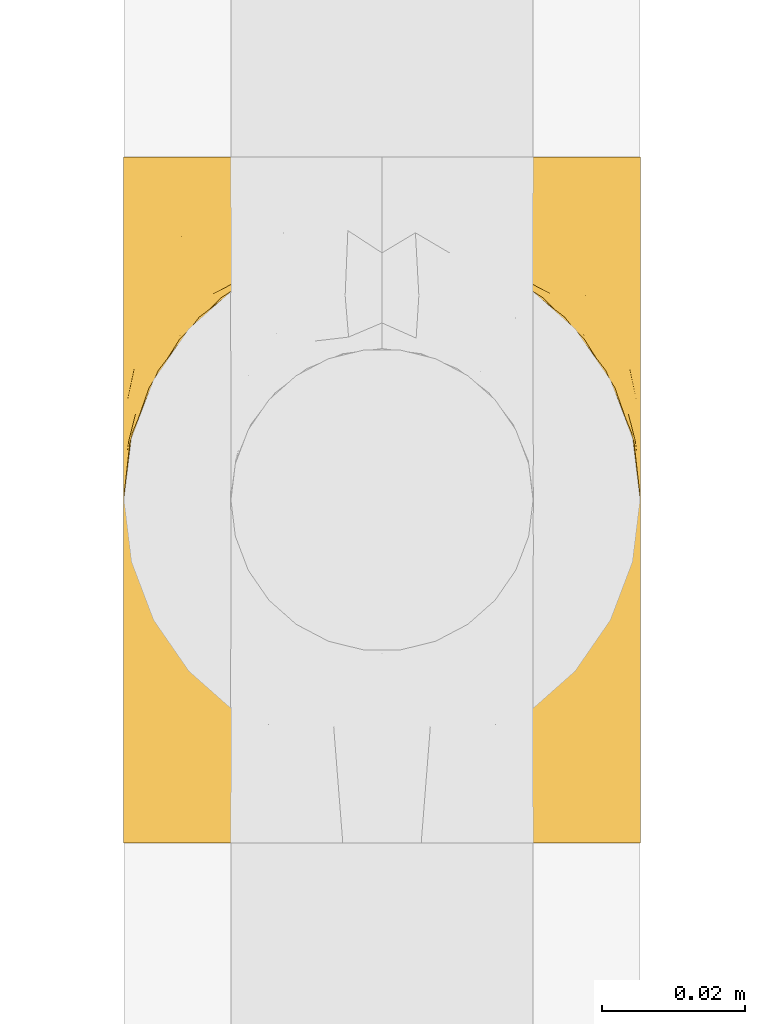
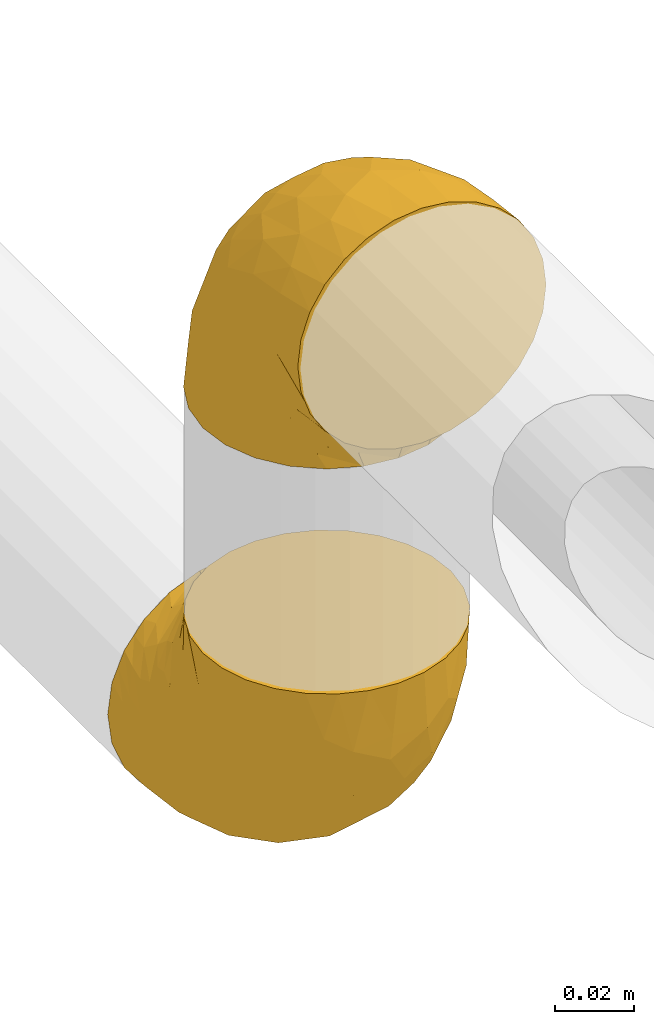
# One storey, part 6 of 39: 2 coverings.
"""IFC2X3 building model written with IfcOpenShell, lengths in millimetres."""

from ifc_helpers import new_model, entity, si_unit, converted_unit, derived_unit, direction, frame, origin, place, context, subcontext, project, spatial, faceted_brep, element, save


model = new_model("IFC2X3")

# Units and contexts
model_context = context("Model", 3, precision=0.01, world=origin(), true_north=direction((6.12303176911189e-17, 1.0)))
body_context = subcontext(model_context, "Body", "Model", "MODEL_VIEW")
ifc_project = project(units=[si_unit("LENGTHUNIT", "METRE", prefix="MILLI"), si_unit("AREAUNIT", "SQUARE_METRE"), si_unit("VOLUMEUNIT", "CUBIC_METRE"), converted_unit("PLANEANGLEUNIT", "DEGREE", entity("IfcRatioMeasure", 0.0174532925199433), si_unit("PLANEANGLEUNIT", "RADIAN"), dimensions=[0, 0, 0, 0, 0, 0, 0]), si_unit("MASSUNIT", "GRAM", prefix="KILO"), derived_unit("MASSDENSITYUNIT", [(si_unit("MASSUNIT", "GRAM", prefix="KILO"), 1), (si_unit("LENGTHUNIT", "METRE"), -3)]), derived_unit("MOMENTOFINERTIAUNIT", [(si_unit("LENGTHUNIT", "METRE"), 4)]), si_unit("TIMEUNIT", "SECOND"), si_unit("FREQUENCYUNIT", "HERTZ"), si_unit("THERMODYNAMICTEMPERATUREUNIT", "DEGREE_CELSIUS"), derived_unit("THERMALTRANSMITTANCEUNIT", [(si_unit("MASSUNIT", "GRAM", prefix="KILO"), 1), (si_unit("THERMODYNAMICTEMPERATUREUNIT", "KELVIN"), -1), (si_unit("TIMEUNIT", "SECOND"), -3)]), derived_unit("VOLUMETRICFLOWRATEUNIT", [(si_unit("LENGTHUNIT", "METRE"), 3), (si_unit("TIMEUNIT", "SECOND"), -1)]), derived_unit("MASSFLOWRATEUNIT", [(si_unit("MASSUNIT", "GRAM", prefix="KILO"), 1), (si_unit("TIMEUNIT", "SECOND"), -1)]), derived_unit("ROTATIONALFREQUENCYUNIT", [(si_unit("TIMEUNIT", "SECOND"), -1)]), si_unit("ELECTRICCURRENTUNIT", "AMPERE"), si_unit("ELECTRICVOLTAGEUNIT", "VOLT"), si_unit("POWERUNIT", "WATT"), si_unit("FORCEUNIT", "NEWTON", prefix="KILO"), si_unit("ILLUMINANCEUNIT", "LUX"), si_unit("LUMINOUSFLUXUNIT", "LUMEN"), si_unit("LUMINOUSINTENSITYUNIT", "CANDELA"), derived_unit("USERDEFINED", [(si_unit("MASSUNIT", "GRAM", prefix="KILO"), -1), (si_unit("LENGTHUNIT", "METRE"), -2), (si_unit("TIMEUNIT", "SECOND"), 3), (si_unit("LUMINOUSFLUXUNIT", "LUMEN"), 1)]), derived_unit("LINEARVELOCITYUNIT", [(si_unit("LENGTHUNIT", "METRE"), 1), (si_unit("TIMEUNIT", "SECOND"), -1)]), si_unit("PRESSUREUNIT", "PASCAL"), derived_unit("USERDEFINED", [(si_unit("LENGTHUNIT", "METRE"), -2), (si_unit("MASSUNIT", "GRAM", prefix="KILO"), 1), (si_unit("TIMEUNIT", "SECOND"), -2)]), derived_unit("LINEARFORCEUNIT", [(si_unit("MASSUNIT", "GRAM", prefix="KILO"), 1), (si_unit("LENGTHUNIT", "METRE"), 1), (si_unit("TIMEUNIT", "SECOND"), -2), (si_unit("LENGTHUNIT", "METRE"), -1)]), derived_unit("PLANARFORCEUNIT", [(si_unit("MASSUNIT", "GRAM", prefix="KILO"), 1), (si_unit("LENGTHUNIT", "METRE"), 1), (si_unit("TIMEUNIT", "SECOND"), -2), (si_unit("LENGTHUNIT", "METRE"), -2)])], contexts=[model_context])

# Site, building, storey
site_placement = place(None, origin())
site = spatial("IfcSite", under=ifc_project, at=site_placement, CompositionType="ELEMENT")
building_placement = place(site_placement, origin())
building = spatial("IfcBuilding", under=site, at=building_placement, CompositionType="ELEMENT")
storey_placement = place(building_placement, frame((0.0, 0.0, 24000.0)))
storey = spatial("IfcBuildingStorey", under=building, at=storey_placement, Name="07", CompositionType="ELEMENT", Elevation=24000.0)

# Coverings
covering_1_placement = place(storey_placement, frame((31042.2, 2084.16, 2622.2)))
element("IfcCovering", 1, at=covering_1_placement, inside=storey, Name=":ADSK_", ObjectType=":ADSK_", PredefinedType="INSULATION", context=body_context, shape_type="Brep", body=[
    faceted_brep([(1.6, 37.8, 85.8), (2.5, 29.74, 85.8), (5.18, 22.08, 85.8), (9.5, 15.22, 85.8), (15.23, 9.49, 85.8), (22.09, 5.18, 85.8), (29.74, 2.5, 85.8), (37.8, 1.6, 85.8), (45.85, 2.5, 85.8), (53.51, 5.18, 85.8), (60.37, 9.5, 85.8), (66.1, 15.23, 85.8), (70.41, 22.09, 85.8), (73.09, 29.74, 85.8), (74.0, 37.8, 85.8), (73.4, 43.06, 85.8), (73.09, 45.85, 85.8), (71.75, 49.68, 85.8), (70.41, 53.51, 85.8), (66.09, 60.37, 85.8), (60.36, 66.1, 85.8), (53.5, 70.41, 85.8), (45.85, 73.09, 85.8), (37.8, 74.0, 85.8), (29.74, 73.09, 85.8), (22.08, 70.41, 85.8), (15.22, 66.09, 85.8), (9.49, 60.36, 85.8), (5.18, 53.5, 85.8), (3.84, 49.67, 85.8), (2.5, 45.85, 85.8), (2.19, 43.06, 85.8), (47.16, 85.8, 72.76), (55.9, 85.8, 69.15), (63.39, 85.8, 63.39), (66.27, 85.8, 59.64), (69.15, 85.8, 55.9), (70.95, 85.8, 51.53), (72.76, 85.8, 47.16), (73.3, 85.8, 43.08), (73.65, 85.8, 40.44), (74.0, 85.8, 37.8), (72.76, 85.8, 28.43), (69.15, 85.8, 19.7), (63.39, 85.8, 12.2), (55.9, 85.8, 6.45), (47.16, 85.8, 2.83), (37.8, 85.8, 1.6), (28.43, 85.8, 2.83), (19.7, 85.8, 6.45), (12.2, 85.8, 12.2), (6.45, 85.8, 19.7), (2.83, 85.8, 28.43), (1.6, 85.8, 37.8), (2.29, 85.8, 43.08), (2.83, 85.8, 47.16), (4.64, 85.8, 51.53), (6.45, 85.8, 55.9), (9.32, 85.8, 59.64), (12.2, 85.8, 63.39), (19.7, 85.8, 69.15), (28.43, 85.8, 72.76), (37.8, 85.8, 74.0), (25.48, 27.78, 27.78), (37.8, 26.99, 26.99), (29.15, 19.15, 36.07), (37.8, 59.78, 5.72), (31.57, 64.45, 4.9), (37.8, 67.99, 4.42), (28.0, 45.3, 13.52), (18.42, 53.86, 14.0), (25.21, 66.01, 6.28), (16.94, 70.92, 9.64), (2.22, 33.16, 70.93), (4.32, 49.16, 36.05), (5.43, 68.28, 24.02), (8.62, 50.64, 25.93), (2.37, 70.36, 32.56), (1.6, 67.43, 41.45), (1.6, 74.88, 39.97), (1.6, 77.61, 39.42), (1.6, 80.34, 38.88), (10.73, 65.68, 16.62), (4.66, 24.84, 71.64), (30.4, 11.5, 47.83), (27.02, 5.67, 65.91), (21.27, 13.35, 51.38), (2.65, 39.73, 52.81), (1.6, 41.45, 67.43), (1.6, 44.05, 63.53), (1.6, 46.65, 59.64), (1.6, 49.25, 55.75), (1.6, 51.85, 51.85), (6.87, 35.98, 41.26), (2.25, 57.18, 38.98), (8.31, 18.48, 70.65), (13.89, 13.36, 65.64), (19.66, 7.85, 71.08), (37.8, 4.42, 67.99), (22.57, 20.15, 38.62), (18.28, 31.91, 28.73), (1.6, 38.88, 80.34), (1.6, 39.97, 74.88), (10.73, 21.9, 52.52), (16.44, 22.4, 41.68), (5.54, 28.44, 56.44), (19.61, 41.69, 19.89), (37.8, 48.04, 11.7), (12.05, 33.67, 34.04), (14.19, 44.49, 22.66), (37.8, 5.72, 59.78), (37.8, 17.68, 36.3), (37.8, 11.7, 48.04), (1.6, 55.75, 49.25), (1.6, 59.64, 46.65), (1.6, 63.53, 44.05), (37.8, 36.3, 17.68), (4.69, 69.92, 56.47), (6.39, 69.03, 60.92), (9.76, 74.68, 63.29), (2.29, 79.55, 45.31), (8.52, 79.54, 59.83), (13.06, 81.25, 64.71), (23.29, 76.19, 74.49), (20.65, 72.4, 76.83), (29.05, 75.54, 78.01), (3.51, 63.7, 56.9), (2.42, 66.91, 50.18), (16.27, 72.9, 71.99), (19.23, 77.88, 70.83), (26.6, 80.8, 73.18), (17.24, 80.78, 68.29), (9.54, 60.93, 80.74), (14.03, 66.56, 78.17), (6.61, 58.7, 73.83), (2.33, 46.01, 76.96), (5.54, 80.23, 54.72), (2.2, 70.42, 47.37), (4.72, 74.75, 54.39), (14.42, 68.99, 74.3), (3.69, 51.42, 75.54), (10.4, 71.01, 66.46), (37.8, 76.08, 80.75), (29.55, 73.72, 81.71), (23.44, 71.61, 81.69), (9.02, 63.33, 72.63), (37.8, 77.45, 77.45), (2.25, 52.1, 62.19), (2.68, 50.98, 67.73), (37.8, 80.75, 76.08), (2.84, 76.87, 48.26), (5.45, 63.89, 62.83), (3.45, 57.77, 62.31), (9.31, 66.53, 68.86), (2.37, 57.73, 56.53), (58.36, 80.78, 68.29), (48.99, 80.8, 73.17), (62.53, 81.26, 64.71), (74.0, 38.88, 80.34), (74.0, 39.97, 74.88), (46.03, 73.72, 81.71), (54.93, 72.41, 76.83), (52.14, 71.61, 81.69), (61.55, 66.57, 78.17), (74.0, 74.88, 39.97), (74.0, 80.34, 38.88), (74.0, 83.07, 38.34), (56.36, 77.88, 70.83), (52.29, 76.2, 74.49), (59.3, 72.91, 72.0), (67.5, 77.2, 59.87), (70.87, 74.75, 54.39), (70.05, 80.23, 54.72), (71.9, 51.43, 75.53), (72.75, 76.87, 48.26), (73.17, 66.92, 50.18), (70.9, 69.93, 56.47), (72.08, 63.71, 56.9), (73.39, 70.42, 47.37), (46.54, 75.54, 78.01), (73.31, 79.55, 45.31), (66.04, 60.94, 80.74), (61.17, 69.0, 74.3), (73.26, 46.02, 76.96), (72.14, 57.77, 62.32), (73.22, 57.73, 56.54), (70.14, 63.89, 62.83), (65.18, 71.03, 66.46), (72.78, 51.53, 67.82), (68.97, 58.72, 73.83), (74.0, 41.45, 67.43), (65.83, 74.69, 63.29), (66.56, 63.35, 72.63), (74.0, 59.64, 46.65), (71.44, 56.44, 67.39), (73.42, 51.59, 62.12), (74.0, 44.05, 63.53), (69.2, 69.03, 60.93), (74.0, 67.43, 41.45), (74.0, 63.53, 44.05), (66.27, 66.54, 68.85), (74.0, 55.75, 49.25), (74.0, 49.25, 55.75), (74.0, 46.65, 59.64), (74.0, 51.85, 51.85), (71.27, 49.16, 36.06), (73.22, 70.36, 32.56), (73.34, 57.19, 38.98), (59.16, 22.41, 41.69), (57.32, 31.92, 28.73), (63.55, 33.68, 34.05), (66.97, 50.63, 25.93), (68.72, 35.99, 41.26), (64.87, 21.91, 52.53), (72.95, 39.73, 52.81), (50.11, 27.78, 27.78), (56.0, 41.7, 19.9), (70.16, 68.28, 24.02), (44.03, 64.45, 4.9), (50.38, 66.0, 6.28), (70.06, 28.45, 56.45), (58.65, 70.92, 9.64), (64.86, 65.68, 16.62), (57.17, 53.85, 14.0), (54.33, 13.35, 51.38), (48.58, 5.67, 65.91), (45.2, 11.5, 47.82), (73.37, 33.16, 70.94), (61.71, 13.37, 65.64), (67.29, 18.49, 70.65), (47.59, 45.3, 13.52), (46.45, 19.14, 36.08), (53.03, 20.15, 38.62), (55.95, 7.85, 71.07), (61.41, 44.48, 22.68), (70.93, 24.85, 71.64)], [[[0, 1, 2, 3, 4, 5, 6, 7, 8, 9, 10, 11, 12, 13, 14, 15, 16, 17, 18, 19, 20, 21, 22, 23, 24, 25, 26, 27, 28, 29, 30, 31]], [[32, 33, 34, 35, 36, 37, 38, 39, 40, 41, 42, 43, 44, 45, 46, 47, 48, 49, 50, 51, 52, 53, 54, 55, 56, 57, 58, 59, 60, 61, 62]], [[63, 64, 65]], [[66, 67, 68]], [[69, 70, 71]], [[71, 70, 72]], [[73, 1, 0]], [[74, 75, 76]], [[49, 48, 71]], [[77, 78, 79, 80, 81, 53]], [[50, 82, 51]], [[72, 50, 49]], [[2, 1, 83]], [[84, 85, 86]], [[87, 88, 89, 90, 91, 92]], [[53, 52, 77]], [[93, 74, 76]], [[5, 85, 6]], [[94, 78, 77]], [[95, 3, 2]], [[95, 96, 3]], [[75, 51, 82]], [[85, 5, 97]], [[50, 72, 82]], [[97, 5, 4]], [[85, 98, 6]], [[94, 87, 92]], [[74, 77, 75]], [[99, 100, 63]], [[96, 4, 3]], [[73, 0, 101, 102, 88]], [[96, 103, 104]], [[48, 68, 67]], [[84, 99, 65]], [[105, 83, 73]], [[105, 95, 83]], [[100, 106, 63]], [[86, 96, 104]], [[97, 86, 85]], [[67, 107, 69]], [[100, 108, 109]], [[84, 110, 85]], [[93, 87, 74]], [[96, 95, 103]], [[69, 71, 67]], [[70, 69, 106]], [[4, 96, 97]], [[86, 97, 96]], [[83, 95, 2]], [[103, 95, 105]], [[93, 103, 105]], [[103, 108, 104]], [[75, 77, 52]], [[94, 77, 74]], [[51, 75, 52]], [[75, 82, 76]], [[109, 82, 70]], [[93, 76, 108]], [[88, 87, 73]], [[105, 73, 87]], [[84, 86, 99]], [[84, 111, 112, 110]], [[98, 85, 110]], [[98, 7, 6]], [[73, 83, 1]], [[71, 72, 49]], [[82, 72, 70]], [[87, 94, 74]], [[94, 92, 113, 114, 115, 78]], [[48, 47, 68]], [[48, 67, 71]], [[100, 104, 108]], [[99, 86, 104]], [[109, 108, 76]], [[100, 109, 106]], [[82, 109, 76]], [[106, 109, 70]], [[100, 99, 104]], [[99, 63, 65]], [[69, 116, 63]], [[111, 84, 65]], [[64, 63, 116]], [[64, 111, 65]], [[63, 106, 69]], [[103, 93, 108]], [[87, 93, 105]], [[107, 67, 66]], [[107, 116, 69]], [[117, 118, 119]], [[80, 120, 55]], [[121, 119, 122]], [[120, 56, 55]], [[123, 124, 125]], [[114, 126, 127]], [[101, 0, 31, 30, 102]], [[123, 128, 124]], [[129, 123, 130]], [[60, 122, 131]], [[132, 133, 134]], [[29, 28, 135]], [[131, 61, 60]], [[122, 60, 59]], [[136, 137, 138]], [[124, 128, 139]], [[132, 27, 26]], [[131, 130, 61]], [[140, 135, 28]], [[102, 29, 135]], [[119, 118, 141]], [[58, 136, 121]], [[140, 28, 27]], [[54, 53, 81, 80, 55]], [[23, 142, 143]], [[24, 144, 25]], [[25, 144, 133]], [[26, 25, 133]], [[134, 133, 145]], [[125, 142, 146]], [[124, 143, 125]], [[147, 90, 148]], [[124, 144, 143]], [[149, 125, 146]], [[150, 57, 56]], [[137, 78, 115]], [[130, 62, 61]], [[132, 140, 27]], [[151, 152, 153]], [[140, 134, 148]], [[148, 89, 140]], [[120, 78, 150]], [[115, 127, 137]], [[137, 136, 150]], [[78, 120, 80, 79]], [[150, 56, 120]], [[91, 154, 92]], [[127, 117, 138]], [[144, 24, 143]], [[133, 144, 124]], [[152, 91, 147]], [[145, 152, 134]], [[23, 143, 24]], [[142, 125, 143]], [[130, 125, 149]], [[128, 123, 129]], [[141, 129, 119]], [[124, 139, 133]], [[125, 130, 123]], [[62, 130, 149]], [[128, 153, 139]], [[145, 139, 153]], [[92, 154, 113]], [[127, 115, 114]], [[117, 127, 126]], [[118, 117, 126]], [[121, 117, 119]], [[138, 137, 127]], [[78, 137, 150]], [[151, 118, 126]], [[118, 151, 141]], [[153, 128, 141]], [[129, 141, 128]], [[102, 30, 29]], [[140, 88, 135]], [[88, 102, 135]], [[133, 132, 26]], [[140, 132, 134]], [[121, 122, 59]], [[131, 119, 129]], [[121, 59, 58]], [[121, 138, 117]], [[136, 58, 57]], [[150, 136, 57]], [[121, 136, 138]], [[119, 131, 122]], [[131, 129, 130]], [[139, 145, 133]], [[152, 145, 153]], [[89, 148, 90]], [[89, 88, 140]], [[147, 134, 152]], [[134, 147, 148]], [[126, 114, 113]], [[152, 154, 91]], [[91, 90, 147]], [[151, 153, 141]], [[154, 151, 126]], [[151, 154, 152]], [[113, 154, 126]], [[155, 32, 156]], [[33, 157, 34]], [[62, 149, 156]], [[15, 14, 158, 159, 16]], [[160, 23, 22]], [[161, 162, 163]], [[40, 39, 38, 164, 165, 166, 41]], [[167, 168, 169]], [[157, 170, 34]], [[171, 172, 170]], [[18, 173, 19]], [[174, 37, 36]], [[175, 176, 177]], [[178, 171, 175]], [[146, 179, 149]], [[168, 179, 161]], [[161, 160, 162]], [[162, 160, 22]], [[38, 37, 180]], [[20, 19, 181]], [[21, 20, 163]], [[161, 182, 169]], [[18, 183, 173]], [[184, 185, 186]], [[169, 187, 167]], [[188, 189, 173]], [[159, 190, 183]], [[17, 159, 183]], [[156, 179, 168]], [[191, 157, 155]], [[192, 163, 189]], [[21, 162, 22]], [[146, 142, 179]], [[181, 163, 20]], [[193, 175, 177]], [[178, 172, 171]], [[167, 156, 168]], [[184, 194, 195]], [[181, 173, 189]], [[173, 196, 188]], [[197, 186, 177]], [[198, 164, 180]], [[180, 164, 38]], [[199, 178, 175]], [[37, 174, 180]], [[198, 180, 174]], [[175, 193, 199]], [[177, 176, 197]], [[163, 162, 21]], [[160, 161, 179]], [[192, 184, 200]], [[194, 189, 188]], [[179, 142, 160]], [[23, 160, 142]], [[169, 168, 161]], [[155, 156, 167]], [[182, 161, 163]], [[200, 186, 187]], [[62, 156, 32]], [[179, 156, 149]], [[192, 182, 163]], [[200, 169, 182]], [[176, 175, 171]], [[174, 178, 198]], [[185, 201, 177]], [[170, 176, 171]], [[197, 176, 191]], [[198, 178, 199]], [[178, 174, 172]], [[187, 197, 191]], [[197, 187, 186]], [[167, 187, 191]], [[169, 200, 187]], [[173, 183, 190]], [[17, 16, 159]], [[173, 181, 19]], [[163, 181, 189]], [[155, 157, 33]], [[170, 157, 191]], [[176, 170, 191]], [[35, 170, 172]], [[35, 172, 36]], [[34, 170, 35]], [[174, 36, 172]], [[32, 155, 33]], [[191, 155, 167]], [[192, 189, 194]], [[182, 192, 200]], [[185, 184, 202]], [[183, 18, 17]], [[196, 173, 190]], [[196, 203, 188]], [[201, 193, 177]], [[200, 184, 186]], [[188, 195, 194]], [[204, 185, 202]], [[188, 203, 195]], [[192, 194, 184]], [[203, 202, 195]], [[184, 195, 202]], [[201, 185, 204]], [[186, 185, 177]], [[205, 206, 207]], [[208, 209, 210]], [[210, 211, 212]], [[210, 213, 208]], [[214, 204, 202, 203, 196, 190]], [[206, 41, 166, 165, 164, 198]], [[215, 216, 209]], [[206, 217, 42]], [[218, 46, 219]], [[207, 214, 205]], [[212, 214, 220]], [[221, 219, 45]], [[45, 219, 46]], [[221, 222, 223]], [[224, 225, 226]], [[222, 44, 43]], [[222, 217, 211]], [[220, 214, 227]], [[227, 190, 159, 158, 14]], [[217, 43, 42]], [[14, 13, 227]], [[225, 9, 8]], [[10, 228, 11]], [[11, 229, 12]], [[208, 213, 228]], [[228, 229, 11]], [[230, 219, 223]], [[231, 232, 226]], [[231, 64, 215]], [[225, 233, 9]], [[229, 213, 220]], [[233, 10, 9]], [[110, 225, 98]], [[41, 206, 42]], [[222, 211, 234]], [[224, 228, 233]], [[225, 8, 98]], [[221, 45, 44]], [[226, 110, 112, 111]], [[12, 229, 235]], [[46, 218, 68]], [[230, 107, 218]], [[223, 234, 216]], [[107, 66, 218]], [[224, 233, 225]], [[228, 10, 233]], [[213, 229, 228]], [[235, 229, 220]], [[208, 228, 224]], [[212, 213, 210]], [[207, 206, 198]], [[205, 211, 217]], [[205, 217, 206]], [[43, 217, 222]], [[212, 211, 205]], [[210, 209, 234]], [[227, 13, 235]], [[214, 190, 227]], [[110, 226, 225]], [[232, 231, 215]], [[8, 7, 98]], [[227, 235, 220]], [[13, 12, 235]], [[222, 221, 44]], [[219, 221, 223]], [[207, 198, 199, 193, 201, 204]], [[214, 207, 204]], [[68, 218, 66]], [[68, 47, 46]], [[230, 218, 219]], [[224, 232, 208]], [[208, 232, 209]], [[216, 215, 230]], [[210, 234, 211]], [[216, 234, 209]], [[222, 234, 223]], [[226, 232, 224]], [[209, 232, 215]], [[226, 111, 231]], [[64, 116, 215]], [[231, 111, 64]], [[116, 230, 215]], [[230, 223, 216]], [[214, 212, 205]], [[213, 212, 220]], [[230, 116, 107]]]),
])
covering_2_placement = place(storey_placement, frame((31042.2, 2072.36, 2775.81)))
element("IfcCovering", 2, at=covering_2_placement, inside=storey, Name=":ADSK_", ObjectType=":ADSK_", PredefinedType="INSULATION", context=body_context, shape_type="Brep", body=[
    faceted_brep([(74.0, 1.6, 49.6), (73.09, 1.6, 57.65), (70.41, 1.6, 65.31), (66.09, 1.6, 72.17), (60.36, 1.6, 77.9), (53.5, 1.6, 82.21), (45.85, 1.6, 84.89), (37.8, 1.6, 85.8), (29.74, 1.6, 84.89), (22.08, 1.6, 82.21), (15.22, 1.6, 77.89), (9.49, 1.6, 72.16), (5.18, 1.6, 65.3), (2.5, 1.6, 57.65), (1.6, 1.6, 49.6), (2.19, 1.6, 44.33), (2.5, 1.6, 41.54), (3.84, 1.6, 37.71), (5.18, 1.6, 33.88), (9.5, 1.6, 27.02), (15.23, 1.6, 21.29), (22.09, 1.6, 16.98), (29.74, 1.6, 14.3), (37.8, 1.6, 13.4), (45.85, 1.6, 14.3), (53.51, 1.6, 16.98), (60.37, 1.6, 21.3), (66.1, 1.6, 27.03), (70.41, 1.6, 33.89), (71.75, 1.6, 37.72), (73.09, 1.6, 41.54), (73.4, 1.6, 44.33), (28.43, 14.63, 1.6), (19.7, 18.25, 1.6), (12.2, 24.0, 1.6), (9.32, 27.75, 1.6), (6.45, 31.5, 1.6), (4.64, 35.86, 1.6), (2.83, 40.23, 1.6), (2.29, 44.31, 1.6), (1.94, 46.95, 1.6), (1.6, 49.6, 1.6), (2.83, 58.96, 1.6), (6.45, 67.7, 1.6), (12.2, 75.19, 1.6), (19.7, 80.95, 1.6), (28.43, 84.56, 1.6), (37.8, 85.8, 1.6), (47.16, 84.56, 1.6), (55.9, 80.95, 1.6), (63.39, 75.19, 1.6), (69.15, 67.7, 1.6), (72.76, 58.96, 1.6), (74.0, 49.6, 1.6), (73.3, 44.31, 1.6), (72.76, 40.23, 1.6), (70.95, 35.86, 1.6), (69.15, 31.5, 1.6), (66.27, 27.75, 1.6), (63.39, 24.0, 1.6), (55.9, 18.25, 1.6), (47.16, 14.63, 1.6), (37.8, 13.4, 1.6), (50.11, 59.61, 59.61), (37.8, 60.4, 60.4), (46.44, 51.32, 68.25), (37.8, 81.67, 27.61), (44.03, 82.49, 22.94), (37.8, 82.98, 19.4), (47.59, 73.87, 42.09), (57.17, 73.39, 33.53), (50.38, 81.11, 21.38), (58.65, 77.75, 16.47), (73.37, 16.46, 54.23), (71.27, 51.34, 38.23), (70.16, 63.37, 19.11), (66.97, 61.46, 36.76), (73.22, 54.83, 17.03), (74.0, 45.94, 19.96), (74.0, 47.42, 12.51), (74.0, 47.97, 9.78), (74.0, 48.51, 7.05), (64.86, 70.77, 21.71), (70.93, 15.75, 62.55), (45.19, 39.56, 75.89), (48.57, 21.48, 81.72), (54.32, 36.01, 74.04), (72.94, 34.58, 47.66), (74.0, 19.96, 45.94), (74.0, 23.86, 43.34), (74.0, 27.75, 40.74), (74.0, 31.64, 38.14), (74.0, 35.54, 35.54), (68.72, 46.13, 51.41), (73.34, 48.41, 30.21), (67.28, 16.74, 68.91), (61.7, 21.75, 74.03), (55.94, 16.31, 79.54), (37.8, 19.4, 82.98), (53.02, 48.77, 67.24), (57.31, 58.66, 55.48), (74.0, 7.05, 48.51), (74.0, 12.51, 47.42), (64.86, 34.87, 65.49), (59.15, 45.71, 64.99), (70.05, 30.95, 58.95), (55.98, 67.5, 45.7), (37.8, 75.69, 39.35), (63.54, 53.35, 53.72), (61.4, 64.73, 42.9), (37.8, 27.61, 81.67), (37.8, 51.09, 69.71), (37.8, 39.35, 75.69), (74.0, 38.14, 31.64), (74.0, 40.74, 27.75), (74.0, 43.34, 23.86), (37.8, 69.71, 51.09), (70.9, 30.92, 17.47), (69.2, 26.47, 18.36), (65.83, 24.1, 12.71), (73.31, 42.08, 7.84), (67.07, 27.56, 7.85), (62.53, 22.68, 6.14), (52.3, 12.9, 11.2), (54.94, 10.56, 14.99), (46.54, 9.38, 11.85), (72.08, 30.49, 23.69), (73.17, 37.21, 20.48), (59.32, 15.4, 14.49), (56.36, 16.56, 9.51), (48.99, 14.21, 6.6), (58.36, 19.1, 6.61), (66.05, 6.65, 26.46), (61.56, 9.22, 20.83), (68.98, 13.56, 28.69), (73.26, 10.43, 41.38), (70.05, 32.68, 7.16), (73.39, 40.02, 16.97), (70.87, 33.01, 12.64), (61.17, 13.09, 18.4), (71.9, 11.85, 35.97), (65.19, 20.93, 16.38), (37.8, 6.64, 11.31), (46.04, 5.68, 13.68), (52.15, 5.7, 15.78), (66.57, 14.76, 24.06), (37.8, 9.94, 9.94), (73.34, 25.2, 35.3), (72.91, 19.66, 36.41), (37.8, 11.31, 6.64), (72.75, 39.13, 10.52), (73.22, 30.86, 29.66), (70.14, 24.56, 23.5), (72.14, 25.09, 29.62), (66.28, 18.54, 20.86), (17.23, 19.1, 6.61), (26.6, 14.22, 6.59), (13.06, 22.68, 6.13), (1.6, 7.05, 48.51), (1.6, 12.51, 47.42), (29.56, 5.68, 13.67), (20.66, 10.57, 14.98), (23.45, 5.7, 15.78), (14.04, 9.22, 20.82), (1.6, 49.05, 4.32), (1.6, 47.42, 12.51), (1.6, 48.51, 7.05), (19.23, 16.56, 9.51), (23.3, 12.9, 11.19), (16.29, 15.39, 14.48), (8.09, 27.52, 10.19), (4.72, 33.0, 12.64), (5.54, 32.67, 7.16), (3.69, 11.86, 35.96), (2.84, 39.13, 10.52), (2.42, 37.21, 20.47), (4.69, 30.92, 17.47), (3.51, 30.49, 23.68), (2.2, 40.02, 16.97), (29.05, 9.38, 11.85), (2.29, 42.08, 7.84), (9.55, 6.65, 26.45), (14.43, 13.09, 18.39), (2.33, 10.43, 41.37), (9.32, 18.54, 20.85), (3.45, 25.08, 29.62), (5.45, 24.56, 23.5), (10.41, 20.93, 16.36), (2.81, 19.57, 35.87), (6.62, 13.56, 28.67), (1.6, 19.96, 45.94), (9.76, 24.1, 12.7), (9.03, 14.76, 24.04), (2.37, 30.85, 29.66), (4.15, 20.0, 30.95), (2.17, 25.27, 35.8), (1.6, 23.86, 43.34), (1.6, 40.74, 27.75), (1.6, 38.14, 31.64), (1.6, 45.94, 19.96), (1.6, 43.34, 23.86), (6.39, 26.46, 18.36), (1.6, 27.75, 40.74), (1.6, 35.54, 35.54), (1.6, 31.64, 38.14), (4.32, 51.33, 38.23), (2.37, 54.83, 17.03), (2.25, 48.41, 30.2), (16.43, 45.7, 64.98), (18.27, 58.67, 55.47), (12.04, 53.34, 53.71), (8.62, 61.46, 36.76), (6.87, 46.13, 51.4), (10.72, 34.86, 65.48), (2.64, 34.58, 47.66), (25.48, 59.61, 59.61), (19.59, 67.49, 45.69), (5.43, 63.37, 19.11), (31.57, 82.49, 22.94), (25.21, 81.11, 21.39), (5.53, 30.94, 58.94), (16.94, 77.75, 16.47), (10.73, 70.77, 21.71), (18.42, 73.39, 33.54), (21.26, 36.01, 74.04), (27.01, 21.48, 81.72), (30.39, 39.57, 75.89), (2.22, 16.45, 54.23), (13.88, 21.75, 74.02), (8.3, 16.74, 68.9), (28.0, 73.87, 42.09), (29.14, 51.31, 68.25), (22.56, 48.77, 67.24), (19.64, 16.32, 79.54), (14.18, 64.71, 42.91), (4.66, 15.75, 62.54)], [[[0, 1, 2, 3, 4, 5, 6, 7, 8, 9, 10, 11, 12, 13, 14, 15, 16, 17, 18, 19, 20, 21, 22, 23, 24, 25, 26, 27, 28, 29, 30, 31]], [[32, 33, 34, 35, 36, 37, 38, 39, 40, 41, 42, 43, 44, 45, 46, 47, 48, 49, 50, 51, 52, 53, 54, 55, 56, 57, 58, 59, 60, 61, 62]], [[63, 64, 65]], [[66, 67, 68]], [[69, 70, 71]], [[71, 70, 72]], [[73, 1, 0]], [[74, 75, 76]], [[49, 48, 71]], [[77, 78, 79, 80, 81, 53]], [[50, 82, 51]], [[72, 50, 49]], [[2, 1, 83]], [[84, 85, 86]], [[87, 88, 89, 90, 91, 92]], [[53, 52, 77]], [[93, 74, 76]], [[5, 85, 6]], [[94, 78, 77]], [[95, 3, 2]], [[95, 96, 3]], [[75, 51, 82]], [[85, 5, 97]], [[50, 72, 82]], [[97, 5, 4]], [[85, 98, 6]], [[94, 87, 92]], [[74, 77, 75]], [[99, 100, 63]], [[96, 4, 3]], [[73, 0, 101, 102, 88]], [[96, 103, 104]], [[48, 68, 67]], [[84, 99, 65]], [[105, 83, 73]], [[105, 95, 83]], [[100, 106, 63]], [[86, 96, 104]], [[97, 86, 85]], [[67, 107, 69]], [[100, 108, 109]], [[84, 110, 85]], [[93, 87, 74]], [[96, 95, 103]], [[69, 71, 67]], [[70, 69, 106]], [[4, 96, 97]], [[86, 97, 96]], [[83, 95, 2]], [[103, 95, 105]], [[93, 103, 105]], [[103, 108, 104]], [[75, 77, 52]], [[94, 77, 74]], [[51, 75, 52]], [[75, 82, 76]], [[109, 82, 70]], [[93, 76, 108]], [[88, 87, 73]], [[105, 73, 87]], [[84, 86, 99]], [[84, 111, 112, 110]], [[98, 85, 110]], [[98, 7, 6]], [[73, 83, 1]], [[71, 72, 49]], [[82, 72, 70]], [[87, 94, 74]], [[94, 92, 113, 114, 115, 78]], [[48, 47, 68]], [[48, 67, 71]], [[100, 104, 108]], [[99, 86, 104]], [[109, 108, 76]], [[100, 109, 106]], [[82, 109, 76]], [[106, 109, 70]], [[100, 99, 104]], [[99, 63, 65]], [[69, 116, 63]], [[111, 84, 65]], [[64, 63, 116]], [[64, 111, 65]], [[63, 106, 69]], [[103, 93, 108]], [[87, 93, 105]], [[107, 67, 66]], [[107, 116, 69]], [[117, 118, 119]], [[80, 120, 55]], [[121, 119, 122]], [[120, 56, 55]], [[123, 124, 125]], [[114, 126, 127]], [[101, 0, 31, 30, 102]], [[123, 128, 124]], [[129, 123, 130]], [[60, 122, 131]], [[132, 133, 134]], [[29, 28, 135]], [[131, 61, 60]], [[122, 60, 59]], [[136, 137, 138]], [[124, 128, 139]], [[132, 27, 26]], [[131, 130, 61]], [[140, 135, 28]], [[102, 29, 135]], [[119, 118, 141]], [[58, 136, 121]], [[140, 28, 27]], [[54, 53, 81, 80, 55]], [[23, 142, 143]], [[24, 144, 25]], [[25, 144, 133]], [[26, 25, 133]], [[134, 133, 145]], [[125, 142, 146]], [[124, 143, 125]], [[147, 90, 148]], [[124, 144, 143]], [[149, 125, 146]], [[150, 57, 56]], [[137, 78, 115]], [[130, 62, 61]], [[132, 140, 27]], [[151, 152, 126]], [[140, 134, 148]], [[148, 89, 140]], [[120, 78, 150]], [[115, 127, 137]], [[150, 137, 136]], [[78, 120, 80, 79]], [[150, 56, 120]], [[153, 152, 151]], [[127, 117, 138]], [[144, 24, 143]], [[133, 144, 124]], [[153, 91, 147]], [[145, 153, 134]], [[23, 143, 24]], [[142, 125, 143]], [[130, 125, 149]], [[128, 123, 129]], [[141, 129, 119]], [[124, 139, 133]], [[125, 130, 123]], [[62, 130, 149]], [[128, 154, 139]], [[145, 139, 154]], [[92, 151, 113]], [[127, 115, 114]], [[117, 127, 126]], [[118, 117, 126]], [[121, 117, 119]], [[138, 137, 127]], [[78, 137, 150]], [[152, 118, 126]], [[118, 152, 141]], [[154, 128, 141]], [[129, 141, 128]], [[102, 30, 29]], [[140, 88, 135]], [[88, 102, 135]], [[133, 132, 26]], [[140, 132, 134]], [[121, 122, 59]], [[131, 119, 129]], [[121, 59, 58]], [[121, 138, 117]], [[121, 136, 138]], [[57, 150, 136]], [[58, 57, 136]], [[119, 131, 122]], [[131, 129, 130]], [[139, 145, 133]], [[153, 145, 154]], [[89, 148, 90]], [[89, 88, 140]], [[147, 134, 153]], [[134, 147, 148]], [[126, 114, 113]], [[153, 151, 91]], [[91, 90, 147]], [[153, 154, 152]], [[152, 154, 141]], [[113, 151, 126]], [[91, 151, 92]], [[155, 32, 156]], [[33, 157, 34]], [[62, 149, 156]], [[15, 14, 158, 159, 16]], [[160, 23, 22]], [[161, 162, 163]], [[164, 41, 40, 39, 38, 165, 166]], [[167, 168, 169]], [[157, 170, 34]], [[171, 172, 170]], [[18, 173, 19]], [[174, 37, 36]], [[175, 176, 177]], [[178, 171, 175]], [[146, 179, 149]], [[168, 179, 161]], [[161, 160, 162]], [[162, 160, 22]], [[38, 37, 180]], [[20, 19, 181]], [[21, 20, 163]], [[161, 182, 169]], [[18, 183, 173]], [[184, 185, 186]], [[169, 187, 167]], [[188, 189, 173]], [[159, 190, 183]], [[17, 159, 183]], [[156, 179, 168]], [[191, 157, 155]], [[192, 163, 189]], [[21, 162, 22]], [[146, 142, 179]], [[181, 163, 20]], [[177, 186, 193]], [[170, 172, 35]], [[167, 156, 168]], [[185, 194, 195]], [[181, 173, 189]], [[173, 196, 188]], [[197, 177, 198]], [[199, 165, 180]], [[180, 165, 38]], [[200, 178, 175]], [[37, 174, 180]], [[199, 180, 174]], [[175, 197, 200]], [[177, 176, 201]], [[163, 162, 21]], [[160, 161, 179]], [[192, 185, 184]], [[194, 189, 188]], [[179, 142, 160]], [[23, 160, 142]], [[169, 168, 161]], [[155, 156, 167]], [[182, 161, 163]], [[184, 186, 187]], [[62, 156, 32]], [[179, 156, 149]], [[192, 182, 163]], [[184, 169, 182]], [[176, 175, 171]], [[174, 178, 199]], [[197, 175, 177]], [[170, 176, 171]], [[201, 176, 191]], [[199, 178, 200]], [[178, 174, 172]], [[187, 201, 191]], [[201, 187, 186]], [[167, 187, 191]], [[169, 184, 187]], [[173, 183, 190]], [[17, 16, 159]], [[173, 181, 19]], [[163, 181, 189]], [[155, 157, 33]], [[170, 157, 191]], [[176, 170, 191]], [[172, 36, 35]], [[172, 174, 36]], [[34, 170, 35]], [[172, 171, 178]], [[32, 155, 33]], [[191, 155, 167]], [[192, 189, 194]], [[182, 192, 184]], [[193, 198, 177]], [[183, 18, 17]], [[196, 173, 190]], [[196, 202, 188]], [[193, 186, 185]], [[201, 186, 177]], [[188, 195, 194]], [[203, 193, 204]], [[188, 202, 195]], [[192, 194, 185]], [[202, 204, 195]], [[185, 195, 204]], [[204, 193, 185]], [[198, 193, 203]], [[205, 206, 207]], [[208, 209, 210]], [[210, 211, 212]], [[210, 213, 208]], [[214, 203, 204, 202, 196, 190]], [[206, 41, 164, 166, 165, 199]], [[215, 216, 209]], [[206, 217, 42]], [[218, 46, 219]], [[207, 214, 205]], [[212, 214, 220]], [[221, 219, 45]], [[45, 219, 46]], [[221, 222, 223]], [[224, 225, 226]], [[222, 44, 43]], [[222, 217, 211]], [[220, 214, 227]], [[227, 190, 159, 158, 14]], [[217, 43, 42]], [[14, 13, 227]], [[225, 9, 8]], [[10, 228, 11]], [[11, 229, 12]], [[208, 213, 228]], [[228, 229, 11]], [[230, 219, 223]], [[231, 232, 226]], [[231, 64, 215]], [[225, 233, 9]], [[229, 213, 220]], [[233, 10, 9]], [[110, 225, 98]], [[41, 206, 42]], [[222, 211, 234]], [[224, 228, 233]], [[225, 8, 98]], [[221, 45, 44]], [[226, 110, 112, 111]], [[12, 229, 235]], [[46, 218, 68]], [[230, 107, 218]], [[223, 234, 216]], [[107, 66, 218]], [[224, 233, 225]], [[228, 10, 233]], [[213, 229, 228]], [[235, 229, 220]], [[208, 228, 224]], [[212, 213, 210]], [[207, 206, 199]], [[205, 211, 217]], [[205, 217, 206]], [[43, 217, 222]], [[212, 211, 205]], [[210, 209, 234]], [[227, 13, 235]], [[214, 190, 227]], [[110, 226, 225]], [[232, 231, 215]], [[8, 7, 98]], [[227, 235, 220]], [[13, 12, 235]], [[222, 221, 44]], [[219, 221, 223]], [[207, 199, 200, 197, 198, 203]], [[214, 207, 203]], [[68, 218, 66]], [[68, 47, 46]], [[230, 218, 219]], [[224, 232, 208]], [[208, 232, 209]], [[216, 215, 230]], [[210, 234, 211]], [[216, 234, 209]], [[222, 234, 223]], [[226, 232, 224]], [[209, 232, 215]], [[226, 111, 231]], [[64, 116, 215]], [[231, 111, 64]], [[116, 230, 215]], [[230, 223, 216]], [[214, 212, 205]], [[213, 212, 220]], [[230, 116, 107]]]),
])

save(model, "model.ifc")
